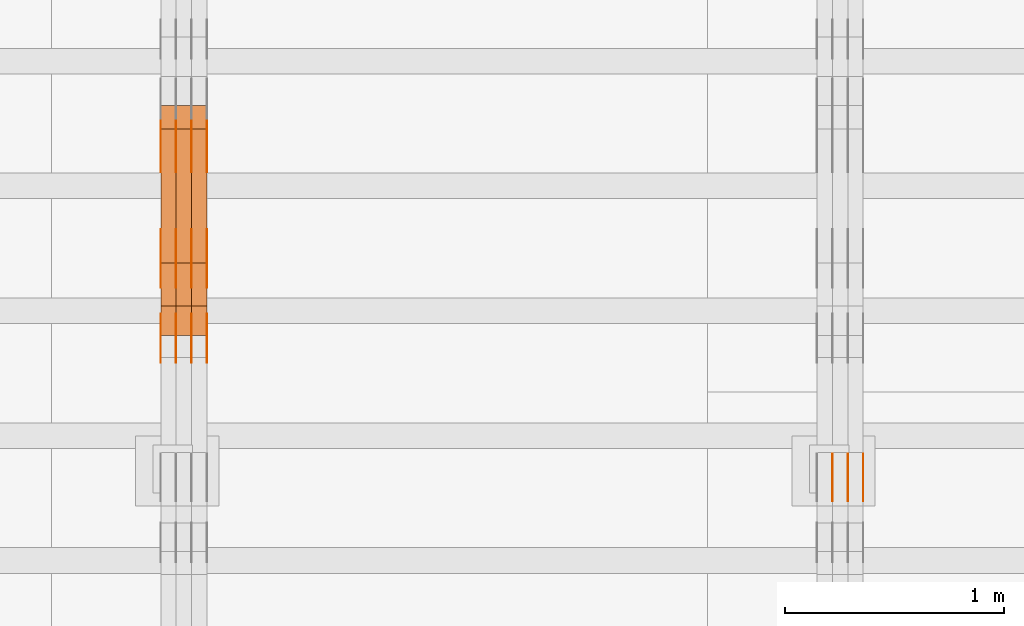
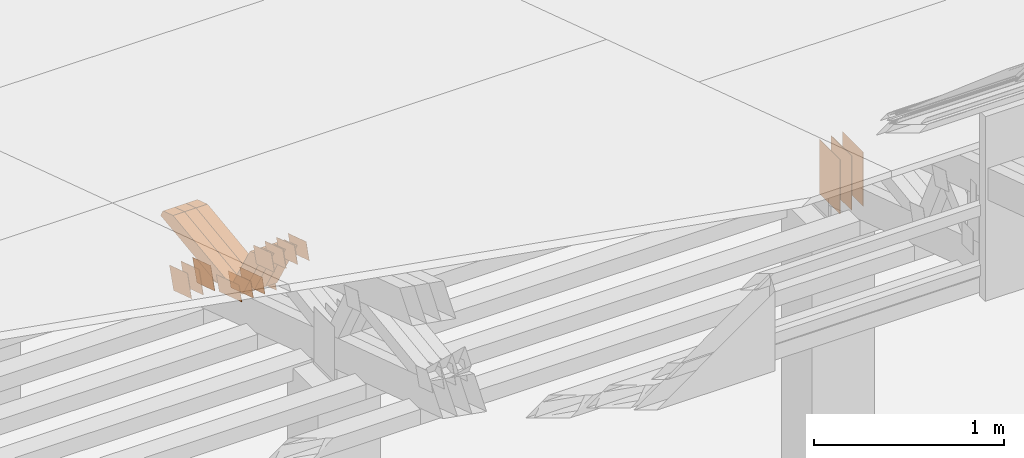
# One storey, part 105 of 385: 29 proxies.
"""IFC2X3 building model written with IfcOpenShell, lengths in millimetres."""

from ifc_helpers import new_model, entity, si_unit, converted_unit, derived_unit, direction, frame, origin, origin_2d_with_axis, place, context, subcontext, project, spatial, polyline, rectangle, outline, extrude, source, transform, mapped, material, type_object, type_shapes, element, save


model = new_model("IFC2X3")

# Units and contexts
model_context = context("Model", 3, precision=0.01, world=origin(), true_north=direction((6.12303176911189e-17, 1.0)))
body_context = subcontext(model_context, "Body", "Model", "MODEL_VIEW")
ifc_project = project(units=[si_unit("LENGTHUNIT", "METRE", prefix="MILLI"), si_unit("AREAUNIT", "SQUARE_METRE"), si_unit("VOLUMEUNIT", "CUBIC_METRE"), converted_unit("PLANEANGLEUNIT", "DEGREE", entity("IfcRatioMeasure", 0.0174532925199433), si_unit("PLANEANGLEUNIT", "RADIAN"), dimensions=[0, 0, 0, 0, 0, 0, 0]), si_unit("MASSUNIT", "GRAM", prefix="KILO"), derived_unit("MASSDENSITYUNIT", [(si_unit("MASSUNIT", "GRAM", prefix="KILO"), 1), (si_unit("LENGTHUNIT", "METRE"), -3)]), si_unit("TIMEUNIT", "SECOND"), si_unit("FREQUENCYUNIT", "HERTZ"), si_unit("THERMODYNAMICTEMPERATUREUNIT", "DEGREE_CELSIUS"), derived_unit("THERMALTRANSMITTANCEUNIT", [(si_unit("MASSUNIT", "GRAM", prefix="KILO"), 1), (si_unit("THERMODYNAMICTEMPERATUREUNIT", "KELVIN"), -1), (si_unit("TIMEUNIT", "SECOND"), -3)]), derived_unit("VOLUMETRICFLOWRATEUNIT", [(si_unit("LENGTHUNIT", "METRE"), 3), (si_unit("TIMEUNIT", "SECOND"), -1)]), si_unit("ELECTRICCURRENTUNIT", "AMPERE"), si_unit("ELECTRICVOLTAGEUNIT", "VOLT"), si_unit("POWERUNIT", "WATT"), si_unit("FORCEUNIT", "NEWTON", prefix="KILO"), si_unit("ILLUMINANCEUNIT", "LUX"), si_unit("LUMINOUSFLUXUNIT", "LUMEN"), si_unit("LUMINOUSINTENSITYUNIT", "CANDELA"), derived_unit("USERDEFINED", [(si_unit("MASSUNIT", "GRAM", prefix="KILO"), -1), (si_unit("LENGTHUNIT", "METRE"), -2), (si_unit("TIMEUNIT", "SECOND"), 3), (si_unit("LUMINOUSFLUXUNIT", "LUMEN"), 1)]), derived_unit("LINEARVELOCITYUNIT", [(si_unit("LENGTHUNIT", "METRE"), 1), (si_unit("TIMEUNIT", "SECOND"), -1)]), si_unit("PRESSUREUNIT", "PASCAL"), derived_unit("USERDEFINED", [(si_unit("LENGTHUNIT", "METRE"), -2), (si_unit("MASSUNIT", "GRAM", prefix="KILO"), 1), (si_unit("TIMEUNIT", "SECOND"), -2)])], contexts=[model_context])

# Site, building, storey
site_placement = place(None, origin())
site = spatial("IfcSite", under=ifc_project, at=site_placement, CompositionType="ELEMENT")
building_placement = place(site_placement, origin())
building = spatial("IfcBuilding", under=site, at=building_placement, CompositionType="ELEMENT")
storey_placement = place(building_placement, origin())
storey = spatial("IfcBuildingStorey", under=building, at=storey_placement, Name="Default", CompositionType="ELEMENT", Elevation=0.0)

# Proxies
ifc_material_1 = material(Name="IfcSurfaceStyle #202642")
building_element_proxy_type_1 = type_object("IfcBuildingElementProxyType", PredefinedType="NOTDEFINED", material=ifc_material_1)
shared_shape_1 = source(origin(), body_context, "Body", "SweptSolid", [
    extrude(rectangle(XDim=350.0, YDim=215.999999999984, at=origin_2d_with_axis()), frame((175.0, 108.0, 0.0), z_axis=(0.0, 0.0, 1.0), x_axis=(-1.0, 0.0, 0.0)), (0.0, 0.0, 1.0), 1.29999999999999),
])
type_shapes(building_element_proxy_type_1, [shared_shape_1])
proxy_1_placement = place(building_placement, frame((15386.3, 17459.2939453125, 3165.36425781251), z_axis=(-1.0, 0.0, 0.0), x_axis=(0.0, 0.0, -1.0)))
element("IfcBuildingElementProxy", 1, at=proxy_1_placement, inside=storey, type_object=building_element_proxy_type_1, material=ifc_material_1, context=body_context, shape_type="MappedRepresentation", body=[
    mapped(shared_shape_1, transform((0.0, 0.0, 0.0), scale=1.0)),
])
ifc_material_2 = material(Name="IfcSurfaceStyle #202585")
building_element_proxy_type_2 = type_object("IfcBuildingElementProxyType", PredefinedType="NOTDEFINED", material=ifc_material_2)
shared_shape_2 = source(origin(), body_context, "Body", "SweptSolid", [
    extrude(rectangle(XDim=350.0, YDim=215.999999999984, at=origin_2d_with_axis()), frame((175.0, 108.0, 0.0), z_axis=(0.0, 0.0, 1.0), x_axis=(-1.0, 0.0, 0.0)), (0.0, 0.0, 1.0), 1.29999999999999),
])
type_shapes(building_element_proxy_type_2, [shared_shape_2])
proxy_2_placement = place(building_placement, frame((15315.0, 17459.2939453125, 3165.36425781251), z_axis=(-1.0, 0.0, 0.0), x_axis=(0.0, 0.0, -1.0)))
element("IfcBuildingElementProxy", 2, at=proxy_2_placement, inside=storey, type_object=building_element_proxy_type_2, material=ifc_material_2, context=body_context, shape_type="MappedRepresentation", body=[
    mapped(shared_shape_2, transform((0.0, 0.0, 0.0), scale=1.0)),
])
ifc_material_3 = material(Name="IfcSurfaceStyle #202528")
building_element_proxy_type_3 = type_object("IfcBuildingElementProxyType", PredefinedType="NOTDEFINED", material=ifc_material_3)
shared_shape_3 = source(origin(), body_context, "Body", "SweptSolid", [
    extrude(rectangle(XDim=350.0, YDim=215.999999999984, at=origin_2d_with_axis()), frame((175.0, 108.0, 0.0), z_axis=(0.0, 0.0, 1.0), x_axis=(-1.0, 0.0, 0.0)), (0.0, 0.0, 1.0), 1.29999999999999),
])
type_shapes(building_element_proxy_type_3, [shared_shape_3])
proxy_3_placement = place(building_placement, frame((15316.3, 17459.2939453125, 3165.36425781251), z_axis=(-1.0, 0.0, 0.0), x_axis=(0.0, 0.0, -1.0)))
element("IfcBuildingElementProxy", 3, at=proxy_3_placement, inside=storey, type_object=building_element_proxy_type_3, material=ifc_material_3, context=body_context, shape_type="MappedRepresentation", body=[
    mapped(shared_shape_3, transform((0.0, 0.0, 0.0), scale=1.0)),
])
ifc_material_4 = material(Name="IfcSurfaceStyle #202471")
building_element_proxy_type_4 = type_object("IfcBuildingElementProxyType", PredefinedType="NOTDEFINED", material=ifc_material_4)
shared_shape_4 = source(origin(), body_context, "Body", "SweptSolid", [
    extrude(rectangle(XDim=350.0, YDim=215.999999999984, at=origin_2d_with_axis()), frame((175.0, 108.0, 0.0), z_axis=(0.0, 0.0, 1.0), x_axis=(-1.0, 0.0, 0.0)), (0.0, 0.0, 1.0), 1.29999999999998),
])
type_shapes(building_element_proxy_type_4, [shared_shape_4])
proxy_4_placement = place(building_placement, frame((15245.0, 17459.2939453125, 3165.36425781251), z_axis=(-1.0, 0.0, 0.0), x_axis=(0.0, 0.0, -1.0)))
element("IfcBuildingElementProxy", 4, at=proxy_4_placement, inside=storey, type_object=building_element_proxy_type_4, material=ifc_material_4, context=body_context, shape_type="MappedRepresentation", body=[
    mapped(shared_shape_4, transform((0.0, 0.0, 0.0), scale=1.0)),
])
ifc_material_5 = material(Name="IfcSurfaceStyle #202414")
building_element_proxy_type_5 = type_object("IfcBuildingElementProxyType", PredefinedType="NOTDEFINED", material=ifc_material_5)
shared_shape_5 = source(origin(), body_context, "Body", "SweptSolid", [
    extrude(rectangle(XDim=350.0, YDim=215.999999999984, at=origin_2d_with_axis()), frame((175.0, 108.0, 0.0), z_axis=(0.0, 0.0, 1.0), x_axis=(-1.0, 0.0, 0.0)), (0.0, 0.0, 1.0), 1.29999999999998),
])
type_shapes(building_element_proxy_type_5, [shared_shape_5])
proxy_5_placement = place(building_placement, frame((15246.3, 17459.2939453125, 3165.36425781251), z_axis=(-1.0, 0.0, 0.0), x_axis=(0.0, 0.0, -1.0)))
element("IfcBuildingElementProxy", 5, at=proxy_5_placement, inside=storey, type_object=building_element_proxy_type_5, material=ifc_material_5, context=body_context, shape_type="MappedRepresentation", body=[
    mapped(shared_shape_5, transform((0.0, 0.0, 0.0), scale=1.0)),
])
ifc_material_6 = material(Name="IfcSurfaceStyle #170262")
building_element_proxy_type_6 = type_object("IfcBuildingElementProxyType", PredefinedType="NOTDEFINED", material=ifc_material_6)
shared_shape_6 = source(origin(), body_context, "Body", "SweptSolid", [
    extrude(outline(polyline([(-125.00031378339, -47.9999612158856), (125.000225258022, -47.9999612158856), (124.999811678525, 47.9999612158856), (-124.999723153156, 47.9999612158856), (-125.00031378339, -47.9999612158856)])), frame((125.000225258022, 48.0000091013474, 0.0), z_axis=(0.0, 0.0, 1.0), x_axis=(-1.0, 0.0, 0.0)), (0.0, 0.0, 1.0), 1.3),
])
type_shapes(building_element_proxy_type_6, [shared_shape_6])
proxy_6_placement = place(building_placement, frame((12386.3, 18456.8597683375, 2657.46691321253), z_axis=(-1.0, 0.0, 0.0), x_axis=(0.0, -0.951056516295124, 0.309016994375039)))
element("IfcBuildingElementProxy", 6, at=proxy_6_placement, inside=storey, type_object=building_element_proxy_type_6, material=ifc_material_6, context=body_context, shape_type="MappedRepresentation", body=[
    mapped(shared_shape_6, transform((0.0, 0.0, 0.0), scale=1.0)),
])
ifc_material_7 = material(Name="IfcSurfaceStyle #170205")
building_element_proxy_type_7 = type_object("IfcBuildingElementProxyType", PredefinedType="NOTDEFINED", material=ifc_material_7)
shared_shape_7 = source(origin(), body_context, "Body", "SweptSolid", [
    extrude(outline(polyline([(-125.00031378339, -47.9999612158856), (125.000225258022, -47.9999612158856), (124.999811678525, 47.9999612158856), (-124.999723153156, 47.9999612158856), (-125.00031378339, -47.9999612158856)])), frame((125.000225258022, 48.0000091013474, 0.0), z_axis=(0.0, 0.0, 1.0), x_axis=(-1.0, 0.0, 0.0)), (0.0, 0.0, 1.0), 1.3),
])
type_shapes(building_element_proxy_type_7, [shared_shape_7])
proxy_7_placement = place(building_placement, frame((12315.0, 18456.8597683375, 2657.46691321253), z_axis=(-1.0, 0.0, 0.0), x_axis=(0.0, -0.951056516295124, 0.309016994375039)))
element("IfcBuildingElementProxy", 7, at=proxy_7_placement, inside=storey, type_object=building_element_proxy_type_7, material=ifc_material_7, context=body_context, shape_type="MappedRepresentation", body=[
    mapped(shared_shape_7, transform((0.0, 0.0, 0.0), scale=1.0)),
])
ifc_material_8 = material(Name="IfcSurfaceStyle #170148")
building_element_proxy_type_8 = type_object("IfcBuildingElementProxyType", PredefinedType="NOTDEFINED", material=ifc_material_8)
shared_shape_8 = source(origin(), body_context, "Body", "SweptSolid", [
    extrude(outline(polyline([(-125.00031378339, -47.9999612158856), (125.000225258022, -47.9999612158856), (124.999811678525, 47.9999612158856), (-124.999723153156, 47.9999612158856), (-125.00031378339, -47.9999612158856)])), frame((125.000225258022, 48.0000091013474, 0.0), z_axis=(0.0, 0.0, 1.0), x_axis=(-1.0, 0.0, 0.0)), (0.0, 0.0, 1.0), 1.3),
])
type_shapes(building_element_proxy_type_8, [shared_shape_8])
proxy_8_placement = place(building_placement, frame((12316.3, 18456.8597683375, 2657.46691321253), z_axis=(-1.0, 0.0, 0.0), x_axis=(0.0, -0.951056516295124, 0.309016994375039)))
element("IfcBuildingElementProxy", 8, at=proxy_8_placement, inside=storey, type_object=building_element_proxy_type_8, material=ifc_material_8, context=body_context, shape_type="MappedRepresentation", body=[
    mapped(shared_shape_8, transform((0.0, 0.0, 0.0), scale=1.0)),
])
ifc_material_9 = material(Name="IfcSurfaceStyle #170091")
building_element_proxy_type_9 = type_object("IfcBuildingElementProxyType", PredefinedType="NOTDEFINED", material=ifc_material_9)
shared_shape_9 = source(origin(), body_context, "Body", "SweptSolid", [
    extrude(outline(polyline([(-125.00031378339, -47.9999612158856), (125.000225258022, -47.9999612158856), (124.999811678525, 47.9999612158856), (-124.999723153156, 47.9999612158856), (-125.00031378339, -47.9999612158856)])), frame((125.000225258022, 48.0000091013474, 0.0), z_axis=(0.0, 0.0, 1.0), x_axis=(-1.0, 0.0, 0.0)), (0.0, 0.0, 1.0), 1.29999999999998),
])
type_shapes(building_element_proxy_type_9, [shared_shape_9])
proxy_9_placement = place(building_placement, frame((12245.0, 18456.8597683375, 2657.46691321253), z_axis=(-1.0, 0.0, 0.0), x_axis=(0.0, -0.951056516295124, 0.309016994375039)))
element("IfcBuildingElementProxy", 9, at=proxy_9_placement, inside=storey, type_object=building_element_proxy_type_9, material=ifc_material_9, context=body_context, shape_type="MappedRepresentation", body=[
    mapped(shared_shape_9, transform((0.0, 0.0, 0.0), scale=1.0)),
])
ifc_material_10 = material(Name="IfcSurfaceStyle #170034")
building_element_proxy_type_10 = type_object("IfcBuildingElementProxyType", PredefinedType="NOTDEFINED", material=ifc_material_10)
shared_shape_10 = source(origin(), body_context, "Body", "SweptSolid", [
    extrude(outline(polyline([(-125.00031378339, -47.9999612158856), (125.000225258022, -47.9999612158856), (124.999811678525, 47.9999612158856), (-124.999723153156, 47.9999612158856), (-125.00031378339, -47.9999612158856)])), frame((125.000225258022, 48.0000091013474, 0.0), z_axis=(0.0, 0.0, 1.0), x_axis=(-1.0, 0.0, 0.0)), (0.0, 0.0, 1.0), 1.29999999999998),
])
type_shapes(building_element_proxy_type_10, [shared_shape_10])
proxy_10_placement = place(building_placement, frame((12246.3, 18456.8597683375, 2657.46691321253), z_axis=(-1.0, 0.0, 0.0), x_axis=(0.0, -0.951056516295124, 0.309016994375039)))
element("IfcBuildingElementProxy", 10, at=proxy_10_placement, inside=storey, type_object=building_element_proxy_type_10, material=ifc_material_10, context=body_context, shape_type="MappedRepresentation", body=[
    mapped(shared_shape_10, transform((0.0, 0.0, 0.0), scale=1.0)),
])
ifc_material_11 = material(Name="IfcSurfaceStyle #169977")
building_element_proxy_type_11 = type_object("IfcBuildingElementProxyType", PredefinedType="NOTDEFINED", material=ifc_material_11)
shared_shape_11 = source(origin(), body_context, "Body", "SweptSolid", [
    extrude(outline(polyline([(-125.00031378339, -47.9999612158856), (125.000225258022, -47.9999612158856), (124.999811678525, 47.9999612158856), (-124.999723153156, 47.9999612158856), (-125.00031378339, -47.9999612158856)])), frame((125.000225258022, 48.0000091013474, 0.0), z_axis=(0.0, 0.0, 1.0), x_axis=(-1.0, 0.0, 0.0)), (0.0, 0.0, 1.0), 1.29999999999998),
])
type_shapes(building_element_proxy_type_11, [shared_shape_11])
proxy_11_placement = place(building_placement, frame((12175.0, 18456.8597683375, 2657.46691321253), z_axis=(-1.0, 0.0, 0.0), x_axis=(0.0, -0.951056516295124, 0.309016994375039)))
element("IfcBuildingElementProxy", 11, at=proxy_11_placement, inside=storey, type_object=building_element_proxy_type_11, material=ifc_material_11, context=body_context, shape_type="MappedRepresentation", body=[
    mapped(shared_shape_11, transform((0.0, 0.0, 0.0), scale=1.0)),
])
ifc_material_12 = material(Name="IfcSurfaceStyle #168552")
building_element_proxy_type_12 = type_object("IfcBuildingElementProxyType", PredefinedType="NOTDEFINED", material=ifc_material_12)
shared_shape_12 = source(origin(), body_context, "Body", "SweptSolid", [
    extrude(outline(polyline([(-99.999796294464, -72.0000050220467), (99.9998768370438, -72.0000050220467), (100.000260677528, 72.0000050220467), (-100.000341220108, 72.0000050220467), (-99.999796294464, -72.0000050220467)])), frame((100.000260677528, 72.0000050220467, 0.0), z_axis=(0.0, 0.0, 1.0), x_axis=(-1.0, 0.0, 0.0)), (0.0, 0.0, 1.0), 1.3),
])
type_shapes(building_element_proxy_type_12, [shared_shape_12])
proxy_12_placement = place(building_placement, frame((12386.3, 18936.3876569477, 2373.90613192527), z_axis=(-1.0, 0.0, 0.0), x_axis=(0.0, -0.951056516295124, 0.309016994375039)))
element("IfcBuildingElementProxy", 12, at=proxy_12_placement, inside=storey, type_object=building_element_proxy_type_12, material=ifc_material_12, context=body_context, shape_type="MappedRepresentation", body=[
    mapped(shared_shape_12, transform((0.0, 0.0, 0.0), scale=1.0)),
])
ifc_material_13 = material(Name="IfcSurfaceStyle #168495")
building_element_proxy_type_13 = type_object("IfcBuildingElementProxyType", PredefinedType="NOTDEFINED", material=ifc_material_13)
shared_shape_13 = source(origin(), body_context, "Body", "SweptSolid", [
    extrude(outline(polyline([(-99.999796294464, -72.0000050220467), (99.9998768370438, -72.0000050220467), (100.000260677528, 72.0000050220467), (-100.000341220108, 72.0000050220467), (-99.999796294464, -72.0000050220467)])), frame((100.000260677528, 72.0000050220467, 0.0), z_axis=(0.0, 0.0, 1.0), x_axis=(-1.0, 0.0, 0.0)), (0.0, 0.0, 1.0), 1.3),
])
type_shapes(building_element_proxy_type_13, [shared_shape_13])
proxy_13_placement = place(building_placement, frame((12315.0, 18936.3876569477, 2373.90613192527), z_axis=(-1.0, 0.0, 0.0), x_axis=(0.0, -0.951056516295124, 0.309016994375039)))
element("IfcBuildingElementProxy", 13, at=proxy_13_placement, inside=storey, type_object=building_element_proxy_type_13, material=ifc_material_13, context=body_context, shape_type="MappedRepresentation", body=[
    mapped(shared_shape_13, transform((0.0, 0.0, 0.0), scale=1.0)),
])
ifc_material_14 = material(Name="IfcSurfaceStyle #168438")
building_element_proxy_type_14 = type_object("IfcBuildingElementProxyType", PredefinedType="NOTDEFINED", material=ifc_material_14)
shared_shape_14 = source(origin(), body_context, "Body", "SweptSolid", [
    extrude(outline(polyline([(-99.999796294464, -72.0000050220467), (99.9998768370438, -72.0000050220467), (100.000260677528, 72.0000050220467), (-100.000341220108, 72.0000050220467), (-99.999796294464, -72.0000050220467)])), frame((100.000260677528, 72.0000050220467, 0.0), z_axis=(0.0, 0.0, 1.0), x_axis=(-1.0, 0.0, 0.0)), (0.0, 0.0, 1.0), 1.3),
])
type_shapes(building_element_proxy_type_14, [shared_shape_14])
proxy_14_placement = place(building_placement, frame((12316.3, 18936.3876569477, 2373.90613192527), z_axis=(-1.0, 0.0, 0.0), x_axis=(0.0, -0.951056516295124, 0.309016994375039)))
element("IfcBuildingElementProxy", 14, at=proxy_14_placement, inside=storey, type_object=building_element_proxy_type_14, material=ifc_material_14, context=body_context, shape_type="MappedRepresentation", body=[
    mapped(shared_shape_14, transform((0.0, 0.0, 0.0), scale=1.0)),
])
ifc_material_15 = material(Name="IfcSurfaceStyle #168381")
building_element_proxy_type_15 = type_object("IfcBuildingElementProxyType", PredefinedType="NOTDEFINED", material=ifc_material_15)
shared_shape_15 = source(origin(), body_context, "Body", "SweptSolid", [
    extrude(outline(polyline([(-99.999796294464, -72.0000050220467), (99.9998768370438, -72.0000050220467), (100.000260677528, 72.0000050220467), (-100.000341220108, 72.0000050220467), (-99.999796294464, -72.0000050220467)])), frame((100.000260677528, 72.0000050220467, 0.0), z_axis=(0.0, 0.0, 1.0), x_axis=(-1.0, 0.0, 0.0)), (0.0, 0.0, 1.0), 1.29999999999998),
])
type_shapes(building_element_proxy_type_15, [shared_shape_15])
proxy_15_placement = place(building_placement, frame((12245.0, 18936.3876569477, 2373.90613192527), z_axis=(-1.0, 0.0, 0.0), x_axis=(0.0, -0.951056516295124, 0.309016994375039)))
element("IfcBuildingElementProxy", 15, at=proxy_15_placement, inside=storey, type_object=building_element_proxy_type_15, material=ifc_material_15, context=body_context, shape_type="MappedRepresentation", body=[
    mapped(shared_shape_15, transform((0.0, 0.0, 0.0), scale=1.0)),
])
ifc_material_16 = material(Name="IfcSurfaceStyle #168324")
building_element_proxy_type_16 = type_object("IfcBuildingElementProxyType", PredefinedType="NOTDEFINED", material=ifc_material_16)
shared_shape_16 = source(origin(), body_context, "Body", "SweptSolid", [
    extrude(outline(polyline([(-99.999796294464, -72.0000050220467), (99.9998768370438, -72.0000050220467), (100.000260677528, 72.0000050220467), (-100.000341220108, 72.0000050220467), (-99.999796294464, -72.0000050220467)])), frame((100.000260677528, 72.0000050220467, 0.0), z_axis=(0.0, 0.0, 1.0), x_axis=(-1.0, 0.0, 0.0)), (0.0, 0.0, 1.0), 1.29999999999998),
])
type_shapes(building_element_proxy_type_16, [shared_shape_16])
proxy_16_placement = place(building_placement, frame((12246.3, 18936.3876569477, 2373.90613192527), z_axis=(-1.0, 0.0, 0.0), x_axis=(0.0, -0.951056516295124, 0.309016994375039)))
element("IfcBuildingElementProxy", 16, at=proxy_16_placement, inside=storey, type_object=building_element_proxy_type_16, material=ifc_material_16, context=body_context, shape_type="MappedRepresentation", body=[
    mapped(shared_shape_16, transform((0.0, 0.0, 0.0), scale=1.0)),
])
ifc_material_17 = material(Name="IfcSurfaceStyle #168267")
building_element_proxy_type_17 = type_object("IfcBuildingElementProxyType", PredefinedType="NOTDEFINED", material=ifc_material_17)
shared_shape_17 = source(origin(), body_context, "Body", "SweptSolid", [
    extrude(outline(polyline([(-99.999796294464, -72.0000050220467), (99.9998768370438, -72.0000050220467), (100.000260677528, 72.0000050220467), (-100.000341220108, 72.0000050220467), (-99.999796294464, -72.0000050220467)])), frame((100.000260677528, 72.0000050220467, 0.0), z_axis=(0.0, 0.0, 1.0), x_axis=(-1.0, 0.0, 0.0)), (0.0, 0.0, 1.0), 1.29999999999999),
])
type_shapes(building_element_proxy_type_17, [shared_shape_17])
proxy_17_placement = place(building_placement, frame((12175.0, 18936.3876569477, 2373.90613192527), z_axis=(-1.0, 0.0, 0.0), x_axis=(0.0, -0.951056516295124, 0.309016994375039)))
element("IfcBuildingElementProxy", 17, at=proxy_17_placement, inside=storey, type_object=building_element_proxy_type_17, material=ifc_material_17, context=body_context, shape_type="MappedRepresentation", body=[
    mapped(shared_shape_17, transform((0.0, 0.0, 0.0), scale=1.0)),
])
ifc_material_18 = material(Name="IfcSurfaceStyle #164106")
building_element_proxy_type_18 = type_object("IfcBuildingElementProxyType", PredefinedType="NOTDEFINED", material=ifc_material_18)
shared_shape_18 = source(origin(), body_context, "Body", "SweptSolid", [
    extrude(outline(polyline([(-99.9999427841299, -54.0000599375792), (99.9996549037756, -54.0000599375792), (100.000407167194, 54.0000599375792), (-100.00011928684, 54.0000599375792), (-99.9999427841299, -54.0000599375792)])), frame((100.000407167194, 54.0000599375792, 0.0), z_axis=(0.0, 0.0, 1.0), x_axis=(-1.0, 0.0, 0.0)), (0.0, 0.0, 1.0), 1.3),
])
type_shapes(building_element_proxy_type_18, [shared_shape_18])
proxy_18_placement = place(building_placement, frame((12386.3, 18065.0682492591, 3072.55239547302), z_axis=(-1.0, 0.0, 0.0), x_axis=(0.0, -0.951056516295154, 0.309016994374948)))
element("IfcBuildingElementProxy", 18, at=proxy_18_placement, inside=storey, type_object=building_element_proxy_type_18, material=ifc_material_18, context=body_context, shape_type="MappedRepresentation", body=[
    mapped(shared_shape_18, transform((0.0, 0.0, 0.0), scale=1.0)),
])
ifc_material_19 = material(Name="IfcSurfaceStyle #164049")
building_element_proxy_type_19 = type_object("IfcBuildingElementProxyType", PredefinedType="NOTDEFINED", material=ifc_material_19)
shared_shape_19 = source(origin(), body_context, "Body", "SweptSolid", [
    extrude(outline(polyline([(-99.9999427841299, -54.0000599375792), (99.9996549037756, -54.0000599375792), (100.000407167194, 54.0000599375792), (-100.00011928684, 54.0000599375792), (-99.9999427841299, -54.0000599375792)])), frame((100.000407167194, 54.0000599375792, 0.0), z_axis=(0.0, 0.0, 1.0), x_axis=(-1.0, 0.0, 0.0)), (0.0, 0.0, 1.0), 1.3),
])
type_shapes(building_element_proxy_type_19, [shared_shape_19])
proxy_19_placement = place(building_placement, frame((12315.0, 18065.0682492591, 3072.55239547302), z_axis=(-1.0, 0.0, 0.0), x_axis=(0.0, -0.951056516295154, 0.309016994374948)))
element("IfcBuildingElementProxy", 19, at=proxy_19_placement, inside=storey, type_object=building_element_proxy_type_19, material=ifc_material_19, context=body_context, shape_type="MappedRepresentation", body=[
    mapped(shared_shape_19, transform((0.0, 0.0, 0.0), scale=1.0)),
])
ifc_material_20 = material(Name="IfcSurfaceStyle #163992")
building_element_proxy_type_20 = type_object("IfcBuildingElementProxyType", PredefinedType="NOTDEFINED", material=ifc_material_20)
shared_shape_20 = source(origin(), body_context, "Body", "SweptSolid", [
    extrude(outline(polyline([(-99.9999427841299, -54.0000599375792), (99.9996549037756, -54.0000599375792), (100.000407167194, 54.0000599375792), (-100.00011928684, 54.0000599375792), (-99.9999427841299, -54.0000599375792)])), frame((100.000407167194, 54.0000599375792, 0.0), z_axis=(0.0, 0.0, 1.0), x_axis=(-1.0, 0.0, 0.0)), (0.0, 0.0, 1.0), 1.3),
])
type_shapes(building_element_proxy_type_20, [shared_shape_20])
proxy_20_placement = place(building_placement, frame((12316.3, 18065.0682492591, 3072.55239547302), z_axis=(-1.0, 0.0, 0.0), x_axis=(0.0, -0.951056516295154, 0.309016994374948)))
element("IfcBuildingElementProxy", 20, at=proxy_20_placement, inside=storey, type_object=building_element_proxy_type_20, material=ifc_material_20, context=body_context, shape_type="MappedRepresentation", body=[
    mapped(shared_shape_20, transform((0.0, 0.0, 0.0), scale=1.0)),
])
ifc_material_21 = material(Name="IfcSurfaceStyle #163935")
building_element_proxy_type_21 = type_object("IfcBuildingElementProxyType", PredefinedType="NOTDEFINED", material=ifc_material_21)
shared_shape_21 = source(origin(), body_context, "Body", "SweptSolid", [
    extrude(outline(polyline([(-99.9999427841299, -54.0000599375792), (99.9996549037756, -54.0000599375792), (100.000407167194, 54.0000599375792), (-100.00011928684, 54.0000599375792), (-99.9999427841299, -54.0000599375792)])), frame((100.000407167194, 54.0000599375792, 0.0), z_axis=(0.0, 0.0, 1.0), x_axis=(-1.0, 0.0, 0.0)), (0.0, 0.0, 1.0), 1.29999999999998),
])
type_shapes(building_element_proxy_type_21, [shared_shape_21])
proxy_21_placement = place(building_placement, frame((12245.0, 18065.0682492591, 3072.55239547302), z_axis=(-1.0, 0.0, 0.0), x_axis=(0.0, -0.951056516295154, 0.309016994374948)))
element("IfcBuildingElementProxy", 21, at=proxy_21_placement, inside=storey, type_object=building_element_proxy_type_21, material=ifc_material_21, context=body_context, shape_type="MappedRepresentation", body=[
    mapped(shared_shape_21, transform((0.0, 0.0, 0.0), scale=1.0)),
])
ifc_material_22 = material(Name="IfcSurfaceStyle #163878")
building_element_proxy_type_22 = type_object("IfcBuildingElementProxyType", PredefinedType="NOTDEFINED", material=ifc_material_22)
shared_shape_22 = source(origin(), body_context, "Body", "SweptSolid", [
    extrude(outline(polyline([(-99.9999427841299, -54.0000599375792), (99.9996549037756, -54.0000599375792), (100.000407167194, 54.0000599375792), (-100.00011928684, 54.0000599375792), (-99.9999427841299, -54.0000599375792)])), frame((100.000407167194, 54.0000599375792, 0.0), z_axis=(0.0, 0.0, 1.0), x_axis=(-1.0, 0.0, 0.0)), (0.0, 0.0, 1.0), 1.29999999999998),
])
type_shapes(building_element_proxy_type_22, [shared_shape_22])
proxy_22_placement = place(building_placement, frame((12246.3, 18065.0682492591, 3072.55239547302), z_axis=(-1.0, 0.0, 0.0), x_axis=(0.0, -0.951056516295154, 0.309016994374948)))
element("IfcBuildingElementProxy", 22, at=proxy_22_placement, inside=storey, type_object=building_element_proxy_type_22, material=ifc_material_22, context=body_context, shape_type="MappedRepresentation", body=[
    mapped(shared_shape_22, transform((0.0, 0.0, 0.0), scale=1.0)),
])
ifc_material_23 = material(Name="IfcSurfaceStyle #163821")
building_element_proxy_type_23 = type_object("IfcBuildingElementProxyType", PredefinedType="NOTDEFINED", material=ifc_material_23)
shared_shape_23 = source(origin(), body_context, "Body", "SweptSolid", [
    extrude(outline(polyline([(-99.9999427841299, -54.0000599375792), (99.9996549037756, -54.0000599375792), (100.000407167194, 54.0000599375792), (-100.00011928684, 54.0000599375792), (-99.9999427841299, -54.0000599375792)])), frame((100.000407167194, 54.0000599375792, 0.0), z_axis=(0.0, 0.0, 1.0), x_axis=(-1.0, 0.0, 0.0)), (0.0, 0.0, 1.0), 1.29999999999999),
])
type_shapes(building_element_proxy_type_23, [shared_shape_23])
proxy_23_placement = place(building_placement, frame((12175.0, 18065.0682492591, 3072.55239547302), z_axis=(-1.0, 0.0, 0.0), x_axis=(0.0, -0.951056516295154, 0.309016994374948)))
element("IfcBuildingElementProxy", 23, at=proxy_23_placement, inside=storey, type_object=building_element_proxy_type_23, material=ifc_material_23, context=body_context, shape_type="MappedRepresentation", body=[
    mapped(shared_shape_23, transform((0.0, 0.0, 0.0), scale=1.0)),
])
ifc_material_24 = material(Name="IfcSurfaceStyle #153954")
building_element_proxy_type_24 = type_object("IfcBuildingElementProxyType", Name="T1-W35 153952", PredefinedType="NOTDEFINED", material=ifc_material_24)
shared_shape_24 = source(origin(), body_context, "Body", "SweptSolid", [
    extrude(outline(polyline([(-196.877231354918, -47.499850828051), (197.289756738813, -47.499850828051), (177.380838136073, -0.000131002767018074), (124.615181369032, 47.4999163294346), (-302.408544889, 47.4999163294346), (-196.877231354918, -47.499850828051)])), frame((197.289756738813, 47.5002438363521, 0.0), z_axis=(0.0, 0.0, 1.0), x_axis=(-1.0, 0.0, 0.0)), (0.0, 0.0, 1.0), 70.0),
])
type_shapes(building_element_proxy_type_24, [shared_shape_24])
proxy_24_placement = place(building_placement, frame((12385.0, 18249.5528960018, 2724.16980022534), z_axis=(-1.0, 0.0, 0.0), x_axis=(0.0, -0.5, 0.866025403784439)))
element("IfcBuildingElementProxy", 24, at=proxy_24_placement, inside=storey, type_object=building_element_proxy_type_24, material=ifc_material_24, Name="T1-W35", context=body_context, shape_type="MappedRepresentation", body=[
    mapped(shared_shape_24, transform((0.0, 0.0, 0.0), scale=1.0)),
])
ifc_material_25 = material(Name="IfcSurfaceStyle #153888")
building_element_proxy_type_25 = type_object("IfcBuildingElementProxyType", Name="T1-W35 153886", PredefinedType="NOTDEFINED", material=ifc_material_25)
shared_shape_25 = source(origin(), body_context, "Body", "SweptSolid", [
    extrude(outline(polyline([(-196.877231354918, -47.499850828051), (197.289756738813, -47.499850828051), (177.380838136073, -0.000131002767018074), (124.615181369032, 47.4999163294346), (-302.408544889, 47.4999163294346), (-196.877231354918, -47.499850828051)])), frame((197.289756738813, 47.5002438363521, 0.0), z_axis=(0.0, 0.0, 1.0), x_axis=(-1.0, 0.0, 0.0)), (0.0, 0.0, 1.0), 70.0),
])
type_shapes(building_element_proxy_type_25, [shared_shape_25])
proxy_25_placement = place(building_placement, frame((12315.0, 18249.5528960018, 2724.16980022534), z_axis=(-1.0, 0.0, 0.0), x_axis=(0.0, -0.5, 0.866025403784439)))
element("IfcBuildingElementProxy", 25, at=proxy_25_placement, inside=storey, type_object=building_element_proxy_type_25, material=ifc_material_25, Name="T1-W35", context=body_context, shape_type="MappedRepresentation", body=[
    mapped(shared_shape_25, transform((0.0, 0.0, 0.0), scale=1.0)),
])
ifc_material_26 = material(Name="IfcSurfaceStyle #153822")
building_element_proxy_type_26 = type_object("IfcBuildingElementProxyType", Name="T1-W35 153820", PredefinedType="NOTDEFINED", material=ifc_material_26)
shared_shape_26 = source(origin(), body_context, "Body", "SweptSolid", [
    extrude(outline(polyline([(-196.877231354918, -47.499850828051), (197.289756738813, -47.499850828051), (177.380838136073, -0.000131002767018074), (124.615181369032, 47.4999163294346), (-302.408544889, 47.4999163294346), (-196.877231354918, -47.499850828051)])), frame((197.289756738813, 47.5002438363521, 0.0), z_axis=(0.0, 0.0, 1.0), x_axis=(-1.0, 0.0, 0.0)), (0.0, 0.0, 1.0), 70.0),
])
type_shapes(building_element_proxy_type_26, [shared_shape_26])
proxy_26_placement = place(building_placement, frame((12245.0, 18249.5528960018, 2724.16980022534), z_axis=(-1.0, 0.0, 0.0), x_axis=(0.0, -0.5, 0.866025403784439)))
element("IfcBuildingElementProxy", 26, at=proxy_26_placement, inside=storey, type_object=building_element_proxy_type_26, material=ifc_material_26, Name="T1-W35", context=body_context, shape_type="MappedRepresentation", body=[
    mapped(shared_shape_26, transform((0.0, 0.0, 0.0), scale=1.0)),
])
ifc_material_27 = material(Name="IfcSurfaceStyle #153558")
building_element_proxy_type_27 = type_object("IfcBuildingElementProxyType", Name="T1-W6 153556", PredefinedType="NOTDEFINED", material=ifc_material_27)
shared_shape_27 = source(origin(), body_context, "Body", "SweptSolid", [
    extrude(outline(polyline([(-485.945461934772, -47.500204767976), (183.41906495488, -47.500204767976), (284.061400026172, 0.000179660053988773), (303.127757064591, 47.500114937949), (-284.66276011087, 47.500114937949), (-485.945461934772, -47.500204767976)])), frame((303.127970456024, 47.5001450766485, 0.0), z_axis=(0.0, 0.0, 1.0), x_axis=(-1.0, 0.0, 0.0)), (0.0, 0.0, 1.0), 70.0),
])
type_shapes(building_element_proxy_type_27, [shared_shape_27])
proxy_27_placement = place(building_placement, frame((12385.0, 19075.4826373647, 2770.72729201433), z_axis=(-1.0, 0.0, 0.0), x_axis=(0.0, -0.991969529622927, -0.126477082112413)))
element("IfcBuildingElementProxy", 27, at=proxy_27_placement, inside=storey, type_object=building_element_proxy_type_27, material=ifc_material_27, Name="T1-W6", context=body_context, shape_type="MappedRepresentation", body=[
    mapped(shared_shape_27, transform((0.0, 0.0, 0.0), scale=1.0)),
])
ifc_material_28 = material(Name="IfcSurfaceStyle #153492")
building_element_proxy_type_28 = type_object("IfcBuildingElementProxyType", Name="T1-W6 153490", PredefinedType="NOTDEFINED", material=ifc_material_28)
shared_shape_28 = source(origin(), body_context, "Body", "SweptSolid", [
    extrude(outline(polyline([(-485.945461934772, -47.500204767976), (183.41906495488, -47.500204767976), (284.061400026172, 0.000179660053988773), (303.127757064591, 47.500114937949), (-284.66276011087, 47.500114937949), (-485.945461934772, -47.500204767976)])), frame((303.127970456024, 47.5001450766485, 0.0), z_axis=(0.0, 0.0, 1.0), x_axis=(-1.0, 0.0, 0.0)), (0.0, 0.0, 1.0), 70.0),
])
type_shapes(building_element_proxy_type_28, [shared_shape_28])
proxy_28_placement = place(building_placement, frame((12315.0, 19075.4826373647, 2770.72729201433), z_axis=(-1.0, 0.0, 0.0), x_axis=(0.0, -0.991969529622927, -0.126477082112413)))
element("IfcBuildingElementProxy", 28, at=proxy_28_placement, inside=storey, type_object=building_element_proxy_type_28, material=ifc_material_28, Name="T1-W6", context=body_context, shape_type="MappedRepresentation", body=[
    mapped(shared_shape_28, transform((0.0, 0.0, 0.0), scale=1.0)),
])
ifc_material_29 = material(Name="IfcSurfaceStyle #153426")
building_element_proxy_type_29 = type_object("IfcBuildingElementProxyType", Name="T1-W6 153424", PredefinedType="NOTDEFINED", material=ifc_material_29)
shared_shape_29 = source(origin(), body_context, "Body", "SweptSolid", [
    extrude(outline(polyline([(-485.945461934772, -47.500204767976), (183.41906495488, -47.500204767976), (284.061400026172, 0.000179660053988773), (303.127757064591, 47.500114937949), (-284.66276011087, 47.500114937949), (-485.945461934772, -47.500204767976)])), frame((303.127970456024, 47.5001450766485, 0.0), z_axis=(0.0, 0.0, 1.0), x_axis=(-1.0, 0.0, 0.0)), (0.0, 0.0, 1.0), 70.0),
])
type_shapes(building_element_proxy_type_29, [shared_shape_29])
proxy_29_placement = place(building_placement, frame((12245.0, 19075.4826373647, 2770.72729201433), z_axis=(-1.0, 0.0, 0.0), x_axis=(0.0, -0.991969529622927, -0.126477082112413)))
element("IfcBuildingElementProxy", 29, at=proxy_29_placement, inside=storey, type_object=building_element_proxy_type_29, material=ifc_material_29, Name="T1-W6", context=body_context, shape_type="MappedRepresentation", body=[
    mapped(shared_shape_29, transform((0.0, 0.0, 0.0), scale=1.0)),
])

save(model, "model.ifc")
